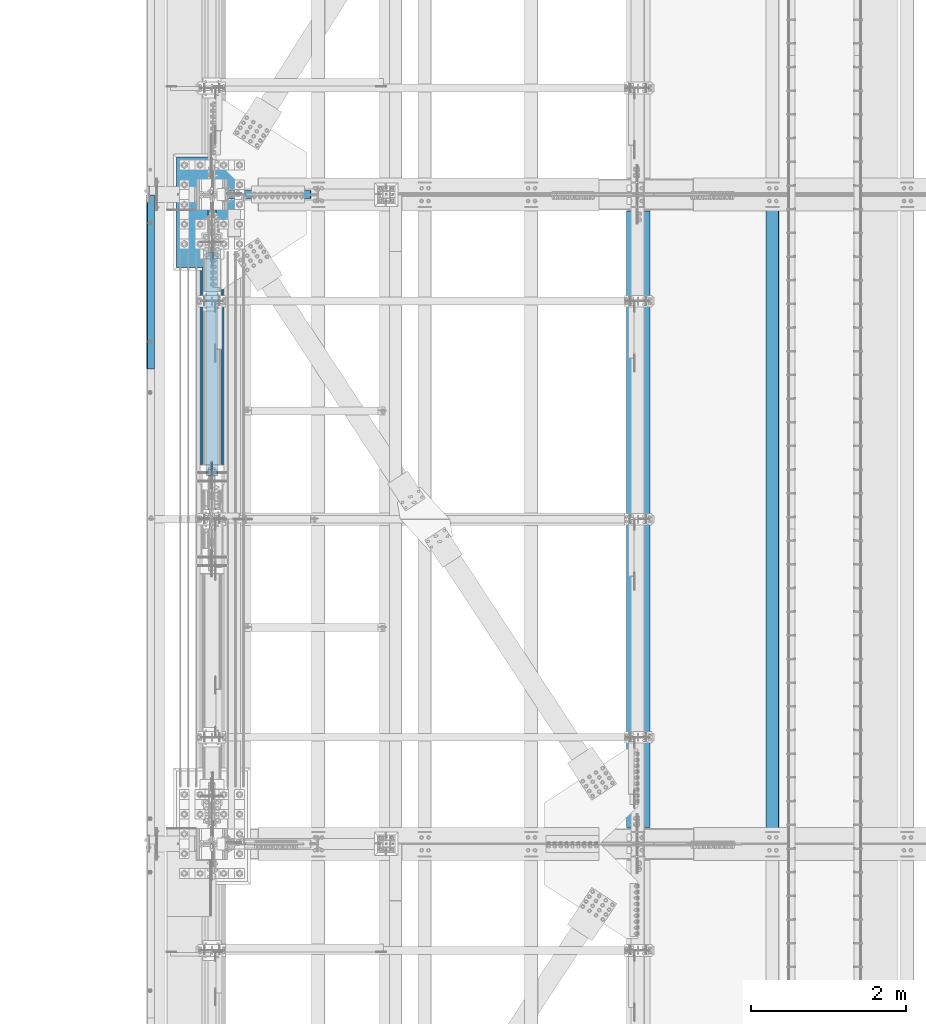
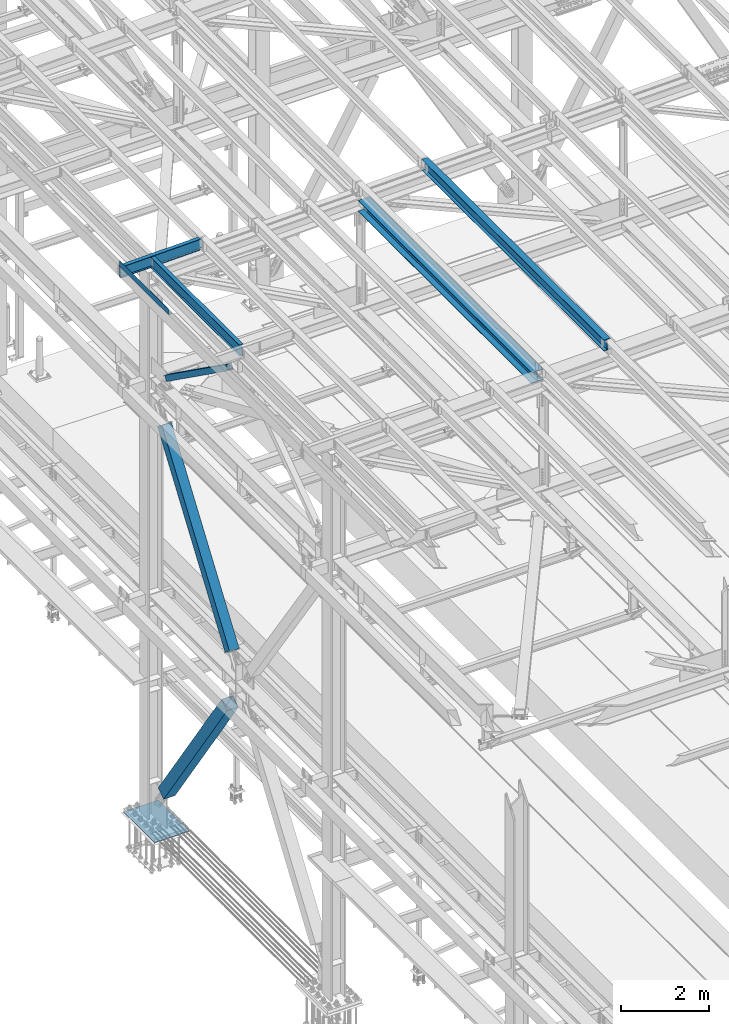
# One storey, part 1872 of 3843: 6 beams, 3 members, 9 elements without a shape of their own.
"""IFC2X3 building model written with IfcOpenShell, lengths in millimetres."""

from ifc_helpers import new_model, si_unit, frame, origin_with_axes, place, context, subcontext, project, spatial, faceted_brep, material, type_object, element, aggregate, save


model = new_model("IFC2X3")

# Units and contexts
model_context = context("Model", 3, precision=1e-05, world=origin_with_axes())
body_context = subcontext(model_context, "Body", "Model", "MODEL_VIEW")
ifc_project = project(units=[si_unit("LENGTHUNIT", "METRE", prefix="MILLI"), si_unit("AREAUNIT", "SQUARE_METRE"), si_unit("VOLUMEUNIT", "CUBIC_METRE"), si_unit("MASSUNIT", "GRAM", prefix="KILO"), si_unit("TIMEUNIT", "SECOND"), si_unit("PLANEANGLEUNIT", "RADIAN"), si_unit("SOLIDANGLEUNIT", "STERADIAN"), si_unit("THERMODYNAMICTEMPERATUREUNIT", "DEGREE_CELSIUS"), si_unit("LUMINOUSINTENSITYUNIT", "LUMEN")], contexts=[model_context])

# Site, building, storey
site_placement = place(None, origin_with_axes())
site = spatial("IfcSite", under=ifc_project, at=site_placement, CompositionType="ELEMENT")
building_placement = place(site_placement, origin_with_axes())
building = spatial("IfcBuilding", under=site, at=building_placement, Name="Undefined", CompositionType="ELEMENT")
storey_placement = place(building_placement, origin_with_axes())
storey = spatial("IfcBuildingStorey", under=building, at=storey_placement, Name="Undefined", CompositionType="ELEMENT", Elevation=0.0)

# Assembly, beam
assembly_1_placement = place(storey_placement, origin_with_axes())
assembly_1 = element("IfcElementAssembly", 1, at=assembly_1_placement, inside=storey, Name="BEAM", AssemblyPlace="NOTDEFINED", PredefinedType="RIGID_FRAME")
ifc_material_1 = material(Name="STEEL/A992")
beam_type_1 = type_object("IfcBeamType", Name="W12X26", PredefinedType="NOTDEFINED")
beam_1_placement = place(assembly_1_placement, frame((43792.659262336, 67272.0069474792, 45765.7787150641), z_axis=(-0.0211520979882261, 0.000687434000021311, 0.99977603301199), x_axis=(2.80000003111667e-08, 0.999999763612031, -0.000687586999733484)))
beam_1 = element("IfcBeam", 2, at=beam_1_placement, type_object=beam_type_1, material=ifc_material_1, Name="BEAM", ObjectType="W12X26", context=body_context, shape_type="Brep", body=[
    faceted_brep([(12.7011867508554, 82.5499999994354, -155.575000000346), (12.6946535115567, 82.5499999997701, -146.050000000309), (8343.89663442646, 82.5499999789899, -146.04999997226), (8343.90319267353, 82.5500000004031, -155.575000008612), (12.6935013104521, 3.17499999993015, -146.050000000505), (8343.89549077737, 3.17499997853884, -146.049999971998), (12.4927018611488, 3.17500000013388, 146.050000000476), (8343.69467136807, 3.17500001817098, 146.04999998054), (12.4938540622534, 82.5499999999884, 146.050000000665), (8343.69582356917, 82.5500000180327, 146.049999980729), (12.4873062541155, 82.5499999999956, 155.575000000696), (8343.68927576105, 82.5500000180327, 155.574999980752), (12.4849096757971, -82.5499999997046, 155.575000000303), (8343.68687918273, -82.5499999816529, 155.574999980374), (12.4914574839349, -82.5499999997119, 146.050000000272), (8343.69342699085, -82.5499999816675, 146.049999980336), (12.4926096850395, -3.17499999985739, 146.050000000454), (8343.69457919199, -3.17499998181302, 146.049999980525), (12.6934091343574, -3.17500000006839, -146.050000000512), (8343.89539928547, -3.17500002148154, -146.049999971976), (12.6922569332237, -82.5499999999156, -146.050000000709), (8343.89425563636, -82.5500000219035, -146.049999971714), (12.6988191383571, -82.5500000002576, -155.574999999757), (8343.90080034929, -82.5500000008251, -155.574999980301)], [[[0, 1, 2, 3]], [[1, 4, 5, 2]], [[4, 6, 7, 5]], [[6, 8, 9, 7]], [[8, 10, 11, 9]], [[10, 12, 13, 11]], [[12, 14, 15, 13]], [[14, 16, 17, 15]], [[16, 18, 19, 17]], [[18, 20, 21, 19]], [[20, 22, 23, 21]], [[22, 0, 3, 23]], [[5, 7, 9, 11, 13, 15, 17, 19, 21, 23, 3, 2]], [[22, 20, 18, 16, 14, 12, 10, 8, 6, 4, 1, 0]]]),
])
aggregate(assembly_1, [beam_1])

assembly_2_placement = place(storey_placement, origin_with_axes())
assembly_2 = element("IfcElementAssembly", 3, at=assembly_2_placement, inside=storey, Name="BEAM", AssemblyPlace="NOTDEFINED", PredefinedType="RIGID_FRAME")
ifc_material_2 = material(Name="STEEL/A36")
beam_type_2 = type_object("IfcBeamType", PredefinedType="NOTDEFINED")
beam_2_placement = place(assembly_2_placement, frame((35839.310111032, 74504.55, 45717.1843160678), z_axis=(0.0, -1.0, 0.0), x_axis=(-0.999776270257024, 0.0, -0.0211520550054595)))
beam_2 = element("IfcBeam", 4, at=beam_2_placement, type_object=beam_type_2, material=ifc_material_2, Name="BENT_PLATE", context=body_context, shape_type="Brep", body=[
    faceted_brep([(-7.27595761418343e-12, -4.77739376947284e-08, 1120.775), (-7.27595761418343e-12, -3.17500000000291, 1117.60000004771), (95.2499999984138, -3.17499999993015, 1117.60000004771), (98.4249999509411, -4.77011781185865e-08, 1120.775), (95.2499999992069, -161.924999997405, 1117.60000004772), (98.4249999517488, -161.924999997391, 1120.775), (-7.27595761418343e-12, -3.17500000000291, -1120.775), (95.2499999984138, -3.17499999993015, -1120.775), (-7.27595761418343e-12, 3.17499999998836, 1120.775), (-7.27595761418343e-12, 3.17499999998836, -1120.775), (101.599999998383, 3.17500000006112, 1120.775), (101.599999998383, 3.17500000006112, -1120.775), (101.599999999198, -161.924999997369, 1120.775), (101.599999999198, -161.924999997369, -1120.775), (95.2499999992069, -161.924999997405, -1120.775)], [[[0, 1, 2, 3]], [[3, 2, 4, 5]], [[6, 7, 2, 1]], [[8, 9, 6, 1, 0]], [[9, 8, 10, 11]], [[11, 10, 12, 13]], [[12, 10, 8, 0, 3, 5]], [[7, 14, 4, 2]], [[7, 6, 9, 11, 13, 14]], [[14, 13, 12, 5, 4]]]),
])
aggregate(assembly_2, [beam_2])

assembly_3_placement = place(storey_placement, origin_with_axes())
assembly_3 = element("IfcElementAssembly", 5, at=assembly_3_placement, inside=storey, Name="BEAM", AssemblyPlace="NOTDEFINED", PredefinedType="RIGID_FRAME")
beam_type_3 = type_object("IfcBeamType", Name="W12X19", PredefinedType="NOTDEFINED")
beam_3_placement = place(assembly_3_placement, frame((35741.5466639417, 75628.5000000002, 45557.9190599814), z_axis=(-0.0243309620078727, 0.0, 0.999703958323549), x_axis=(0.999703958323549, 0.0, 0.0243309620078731)))
beam_3 = element("IfcBeam", 6, at=beam_3_placement, type_object=beam_type_3, material=ifc_material_1, Name="BEAM", ObjectType="W12X19", context=body_context, shape_type="Brep", body=[
    faceted_brep([(2104.49644602991, -3.17500000000291, -144.462500005306), (2104.49644602991, -50.8000000000029, -144.462500005306), (2104.46615934558, -50.8000000000029, -153.987500005322), (2104.46615934558, 50.8000000000029, -153.987500005322), (2104.49644602991, 50.8000000000029, -144.462500005306), (2104.49644602991, 3.17500000000291, -144.462500005306), (2104.50753585254, 3.17500000000291, -140.974810188054), (2104.50753585254, -3.17500000000291, -140.974810188054), (2105.48971442616, 3.17500000000291, -136.117829138602), (2105.48971442616, -3.17500000000291, -136.117829138602), (2108.25581528653, 3.17500000000291, -132.006427224958), (2108.25581528653, -3.17500000000291, -132.006427224958), (2112.38472465244, 3.17500000000291, -129.266528118555), (2112.38472465244, -3.17500000000291, -129.266528118555), (2117.24785350157, 3.17500000000291, -128.315256621056), (2117.24785350157, -3.17500000000291, -128.315256621056), (2187.09750056666, -3.17500000000291, -128.537357850546), (2187.09750056666, 3.17500000000291, -128.537357850546), (4.36557456851006e-11, 3.17500000000291, 144.462499999994), (4.36557456851006e-11, 50.8000000000029, 144.462499999994), (2105.41514961354, 50.8000000000029, 144.462500000773), (2105.41514961354, 3.17500000000291, 144.462500000773), (-3.63797880709171e-11, -50.8000000000029, -153.987499999988), (-3.63797880709171e-11, -50.8000000000029, -144.46249999998), (-3.63797880709171e-11, -3.17500000000291, -144.46249999998), (4.36557456851006e-11, -3.17500000000291, 144.462499999994), (4.36557456851006e-11, -50.8000000000029, 144.462499999994), (3.63797880709171e-11, -50.8000000000029, 153.987499999988), (3.63797880709171e-11, 50.8000000000029, 153.987499999988), (-3.63797880709171e-11, 3.17500000000291, -144.46249999998), (-3.63797880709171e-11, 50.8000000000029, -144.46249999998), (-3.63797880709171e-11, 50.8000000000029, -153.987499999988), (2105.41514961354, -3.17500000000291, 144.462500000773), (2105.41514961354, -50.8000000000029, 144.462500000773), (2105.44538605725, -50.8000000000029, 153.987500000767), (2105.44538605725, 50.8000000000029, 153.987500000767), (2105.40603627673, -3.17500000000291, 141.598760949964), (2105.40603627673, 3.17500000000291, 141.598760949964), (2106.35730777424, -3.17500000000291, 136.735632100834), (2106.35730777424, 3.17500000000291, 136.735632100834), (2109.09720688066, -3.17500000000291, 132.606722734927), (2109.09720688066, 3.17500000000291, 132.606722734927), (2113.20860879429, -3.17500000000291, 129.840621874551), (2113.20860879429, 3.17500000000291, 129.840621874551), (2118.06558984374, -3.17500000000291, 128.858443300931), (2118.06558984374, 3.17500000000291, 128.858443300931), (2187.91523691027, -3.17500000000291, 128.636342071433), (2187.91523691027, 3.17500000000291, 128.636342071433)], [[[0, 1, 2, 3, 4, 5, 6, 7]], [[7, 6, 8, 9]], [[9, 8, 10, 11]], [[11, 10, 12, 13]], [[13, 12, 14, 15]], [[16, 15, 14, 17]], [[18, 19, 20, 21]], [[22, 23, 24, 25, 26, 27, 28, 19, 18, 29, 30, 31]], [[26, 25, 32, 33]], [[27, 26, 33, 34]], [[28, 27, 34, 35]], [[19, 28, 35, 20]], [[34, 33, 32, 36, 37, 21, 20, 35]], [[38, 39, 37, 36]], [[40, 41, 39, 38]], [[42, 43, 41, 40]], [[44, 45, 43, 42]], [[46, 47, 45, 44]], [[47, 46, 16, 17]], [[12, 10, 8, 6, 5, 29, 18, 21, 37, 39, 41, 43, 45, 47, 17, 14]], [[30, 29, 5, 4]], [[31, 30, 4, 3]], [[22, 31, 3, 2]], [[23, 22, 2, 1]], [[24, 23, 1, 0]], [[46, 44, 42, 40, 38, 36, 32, 25, 24, 0, 7, 9, 11, 13, 15, 16]]]),
])
aggregate(assembly_3, [beam_3])

assembly_4_placement = place(storey_placement, origin_with_axes())
assembly_4 = element("IfcElementAssembly", 7, at=assembly_4_placement, inside=storey, Name="BEAM", AssemblyPlace="NOTDEFINED", PredefinedType="RIGID_FRAME")
beam_4_placement = place(assembly_4_placement, frame((36575.9999999884, 71450.2, 45575.6071293693), z_axis=(0.0, 0.0, 1.0), x_axis=(0.0, 1.0, 0.0)))
beam_4 = element("IfcBeam", 8, at=beam_4_placement, type_object=beam_type_3, material=ifc_material_1, Name="BEAM", ObjectType="W12X19", context=body_context, shape_type="Brep", body=[
    faceted_brep([(4111.62499999991, -3.17500000000291, -144.462500000001), (4111.62499999991, -50.8000000000029, -144.462500000001), (4111.62499999991, -50.8000000000029, -153.987500000003), (4111.62499999991, 50.8000000000029, -153.987500000003), (4111.62499999991, 50.8000000000029, -144.462500000001), (4111.62499999991, 3.17500000000291, -144.462500000001), (4111.62499999991, 3.17500000000291, -141.287499808204), (4111.62499999991, -3.17500000000291, -141.287499808204), (4112.5917299225, 3.17500000000291, -136.427420290158), (4112.5917299225, -3.17500000000291, -136.427420290158), (4115.34474382298, 3.17500000000291, -132.307243822004), (4115.34474382298, -3.17500000000291, -132.307243822004), (4119.46492029114, 3.17500000000291, -129.55422992153), (4119.46492029114, -3.17500000000291, -129.55422992153), (4124.32499980918, 3.17500000000291, -128.587499998939), (4124.32499980918, -3.17500000000291, -128.587499998939), (4162.42499999992, -3.17500000000291, -128.587499998939), (4162.42499999992, 3.17500000000291, -128.587499998939), (4111.62499999991, 50.8000000000029, 144.462500000001), (4111.62499999991, 3.17500000000291, 144.462500000001), (66.6750000000175, 3.17500000000291, 144.462500000001), (66.6750000000175, 50.8000000000029, 144.462500000001), (66.6750000000175, -3.17500000000291, -141.287499808226), (66.6750000000175, 3.17500000000291, -141.287499808226), (66.6750000000175, 3.17500000000291, -144.462500000001), (66.6750000000175, 50.8000000000029, -144.462500000001), (66.6750000000175, 50.8000000000029, -153.987500000003), (66.6750000000175, -50.8000000000029, -153.987500000003), (66.6750000000175, -50.8000000000029, -144.462500000001), (66.6750000000175, -3.17500000000291, -144.462500000001), (65.7082700774336, -3.17500000000291, -136.42742029018), (65.7082700774336, 3.17500000000291, -136.42742029018), (62.9552561769524, -3.17500000000291, -132.307243822026), (62.9552561769524, 3.17500000000291, -132.307243822026), (58.8350797087915, -3.17500000000291, -129.554229921552), (58.8350797087915, 3.17500000000291, -129.554229921552), (53.9750001907523, -3.17500000000291, -128.587499998961), (53.9750001907523, 3.17500000000291, -128.587499998961), (15.8750000000146, -3.17500000000291, -128.587499998961), (15.8750000000146, 3.17500000000291, -128.587499998961), (15.8750000000146, -3.17500000000291, 128.587500001042), (15.8750000000146, 3.17500000000291, 128.587500001042), (15.8750000000146, 3.17500000000291, 115.887500001612), (15.8750000000146, 3.17500000000291, -114.712499998386), (53.9750001907523, -3.17500000000291, 128.587500001042), (53.9750001907523, 3.17500000000291, 128.587500001042), (58.8350797087915, -3.17500000000291, 129.554229923633), (58.8350797087915, 3.17500000000291, 129.554229923633), (62.9552561769524, -3.17500000000291, 132.307243824107), (62.9552561769524, 3.17500000000291, 132.307243824107), (65.7082700774336, -3.17500000000291, 136.427420292261), (65.7082700774336, 3.17500000000291, 136.427420292261), (66.6750000000175, -3.17500000000291, 141.287499810307), (66.6750000000175, 3.17500000000291, 141.287499810307), (66.6750000000175, -50.8000000000029, 153.987500000003), (66.6750000000175, 50.8000000000029, 153.987500000003), (66.6750000000175, -3.17500000000291, 144.462500000001), (66.6750000000175, -50.8000000000029, 144.462500000001), (4111.62499999991, -3.17500000000291, 144.462500000001), (4111.62499999991, -50.8000000000029, 144.462500000001), (4111.62499999991, -50.8000000000029, 153.987500000003), (4111.62499999991, 50.8000000000029, 153.987500000003), (4111.62499999991, -3.17500000000291, 141.287499810329), (4111.62499999991, 3.17500000000291, 141.287499810329), (4112.5917299225, -3.17500000000291, 136.427420292282), (4112.5917299225, 3.17500000000291, 136.427420292282), (4115.34474382298, -3.17500000000291, 132.307243824129), (4115.34474382298, 3.17500000000291, 132.307243824129), (4119.46492029114, -3.17500000000291, 129.554229923655), (4119.46492029114, 3.17500000000291, 129.554229923655), (4124.32499980918, -3.17500000000291, 128.587500001064), (4124.32499980918, 3.17500000000291, 128.587500001064), (4162.42499999992, -3.17500000000291, 128.587500001064), (4162.42499999992, 3.17500000000291, 128.587500001064), (4162.42499999992, 3.17500000000291, -114.712499998423), (4162.42499999992, 3.17500000000291, 115.887500001576)], [[[0, 1, 2, 3, 4, 5, 6, 7]], [[7, 6, 8, 9]], [[9, 8, 10, 11]], [[11, 10, 12, 13]], [[13, 12, 14, 15]], [[16, 15, 14, 17]], [[18, 19, 20, 21]], [[22, 23, 24, 25, 26, 27, 28, 29]], [[30, 31, 23, 22]], [[32, 33, 31, 30]], [[34, 35, 33, 32]], [[36, 37, 35, 34]], [[38, 39, 37, 36]], [[40, 41, 42, 43, 39, 38]], [[44, 45, 41, 40]], [[46, 47, 45, 44]], [[48, 49, 47, 46]], [[50, 51, 49, 48]], [[52, 53, 51, 50]], [[54, 55, 21, 20, 53, 52, 56, 57]], [[58, 59, 57, 56]], [[59, 60, 54, 57]], [[60, 61, 55, 54]], [[61, 18, 21, 55]], [[60, 59, 58, 62, 63, 19, 18, 61]], [[64, 65, 63, 62]], [[66, 67, 65, 64]], [[68, 69, 67, 66]], [[70, 71, 69, 68]], [[72, 73, 71, 70]], [[74, 75, 73, 72, 16, 17]], [[33, 35, 37, 39, 43, 42, 41, 45, 47, 49, 51, 53, 20, 19, 63, 65, 67, 69, 71, 73, 75, 74, 17, 14, 12, 10, 8, 6, 5, 24, 23, 31]], [[5, 4, 25, 24]], [[4, 3, 26, 25]], [[3, 2, 27, 26]], [[2, 1, 28, 27]], [[1, 0, 29, 28]], [[0, 7, 9, 11, 13, 15, 16, 72, 70, 68, 66, 64, 62, 58, 56, 52, 50, 48, 46, 44, 40, 38, 36, 34, 32, 30, 22, 29]]]),
])
aggregate(assembly_4, [beam_4])

# Assembly, member
assembly_5_placement = place(storey_placement, origin_with_axes())
assembly_5 = element("IfcElementAssembly", 9, at=assembly_5_placement, inside=storey, Name="None", AssemblyPlace="NOTDEFINED", PredefinedType="RIGID_FRAME")
member_type_1 = type_object("IfcMemberType", Name="HSS10X10X1/4", PredefinedType="NOTDEFINED")
member_1_placement = place(assembly_5_placement, frame((36576.0, 71932.0945853412, 36941.8524737922), z_axis=(1.0, 0.0, 0.0), x_axis=(0.0, 0.572746499261054, 0.819732546373637)))
member_1 = element("IfcMember", 10, at=member_1_placement, type_object=member_type_1, material=ifc_material_1, Name="None", ObjectType="HSS10X10X1/4", context=body_context, shape_type="Brep", body=[
    faceted_brep([(2.00088834390044e-10, 120.650000000089, -120.649999999994), (-2.03726813197136e-10, -120.650000000081, -120.649999999994), (5403.85000024675, -120.650000015012, -120.650000000001), (5403.85000024701, 120.649999984038, -120.650000000001), (-2.03726813197136e-10, -120.650000000081, 120.649999999994), (5403.85000024675, -120.650000015012, 120.650000000001), (2.00088834390044e-10, 120.650000000089, 120.649999999994), (5403.85000024701, 120.649999984038, 120.650000000001), (2.16459739021957e-10, 127.000000000087, -127.0), (2.16459739021957e-10, 127.000000000087, 127.0), (5403.85000024701, 126.999999984007, 127.0), (5403.85000024701, 126.999999984007, -127.0), (-2.14640749618411e-10, -127.00000000008, 127.0), (5403.85000024675, -127.000000014988, 127.0), (-2.14640749618411e-10, -127.00000000008, -127.0), (5403.85000024675, -127.000000014988, -127.0)], [[[0, 1, 2, 3]], [[1, 4, 5, 2]], [[4, 6, 7, 5]], [[6, 0, 3, 7]], [[8, 9, 10, 11]], [[9, 12, 13, 10]], [[12, 14, 15, 13]], [[14, 8, 11, 15]], [[13, 15, 11, 10], [5, 7, 3, 2]], [[14, 12, 9, 8], [6, 4, 1, 0]]]),
])
aggregate(assembly_5, [member_1])

assembly_6_placement = place(storey_placement, origin_with_axes())
assembly_6 = element("IfcElementAssembly", 11, at=assembly_6_placement, inside=storey, Name="None", AssemblyPlace="NOTDEFINED", PredefinedType="RIGID_FRAME")
member_type_2 = type_object("IfcMemberType", Name="HSS12X12X5/16", PredefinedType="NOTDEFINED")
member_2_placement = place(assembly_6_placement, frame((36576.0000061035, 74926.1485506377, 31186.1398748412), z_axis=(-1.0, 0.0, 0.0), x_axis=(0.0, -0.565762265008601, 0.824568408012542)))
member_2 = element("IfcMember", 12, at=member_2_placement, type_object=member_type_2, material=ifc_material_1, Name="None", ObjectType="HSS12X12X5/16", context=body_context, shape_type="Brep", body=[
    faceted_brep([(-2.61934474110603e-10, 144.462500000002, -144.462500000001), (2.61934474110603e-10, -144.462499999993, -144.462500000001), (5124.45041186737, -144.462499974092, -144.462500000001), (5124.45041186616, 144.462500026799, -144.462500000001), (2.61934474110603e-10, -144.462499999993, 144.462500000001), (5124.45041186737, -144.462499974092, 144.462500000001), (-2.61934474110603e-10, 144.462500000002, 144.462500000001), (5124.45041186616, 144.462500026799, 144.462500000001), (-2.7648638933897e-10, 152.400000000002, -152.400000000001), (-2.7648638933897e-10, 152.400000000002, 152.400000000001), (5124.45041186612, 152.400000026828, 152.400000000001), (5124.45041186612, 152.400000026828, -152.400000000001), (2.83762346953154e-10, -152.399999999993, 152.400000000001), (5124.4504118674, -152.399999974121, 152.400000000001), (2.83762346953154e-10, -152.399999999993, -152.400000000001), (5124.4504118674, -152.399999974121, -152.400000000001)], [[[0, 1, 2, 3]], [[1, 4, 5, 2]], [[4, 6, 7, 5]], [[6, 0, 3, 7]], [[8, 9, 10, 11]], [[9, 12, 13, 10]], [[12, 14, 15, 13]], [[14, 8, 11, 15]], [[13, 15, 11, 10], [5, 7, 3, 2]], [[14, 12, 9, 8], [6, 4, 1, 0]]]),
])
aggregate(assembly_6, [member_2])

assembly_7_placement = place(storey_placement, origin_with_axes())
assembly_7 = element("IfcElementAssembly", 13, at=assembly_7_placement, inside=storey, AssemblyPlace="NOTDEFINED", PredefinedType="RIGID_FRAME")
ifc_material_3 = material()
member_type_3 = type_object("IfcMemberType", Name="HSS6X6X3/8", PredefinedType="NOTDEFINED")
member_3_placement = place(assembly_7_placement, frame((36575.9999999316, 71450.2000002264, 45210.4124997862), z_axis=(1.0, 0.0, 0.0), x_axis=(0.0, 0.814318393718894, -0.580418429799641)))
member_3 = element("IfcMember", 14, at=member_3_placement, type_object=member_type_3, material=ifc_material_3, ObjectType="HSS6X6X3/8", context=body_context, shape_type="Brep", body=[
    faceted_brep([(735.102363335427, -76.2000000014959, 7.93750000002183), (735.10236333542, -66.6750000014727, 7.93750000002183), (835.114863341114, -66.6750000016327, 7.93750000002183), (835.114863341099, -76.2000000016706, 7.93750000002183), (838.152413085547, -66.6750000016473, 7.33329378932831), (838.152413085525, -76.2000000016706, 7.33329378932831), (840.727523416841, -66.6750000016473, 5.61266007569066), (840.727523416834, -76.2000000016706, 5.61266007569066), (842.4481571305, -66.6750000016473, 3.03754974441836), (842.448157130493, -76.2000000016851, 3.03754974441836), (835.114863341099, -76.2000000016706, -7.93749999997817), (835.114863341114, -66.6750000016327, -7.93749999997817), (735.10236333542, -66.6750000014727, -7.93749999997817), (735.102363335427, -76.2000000014959, -7.93749999997817), (838.152413085525, -76.2000000016706, -7.33329378928465), (838.152413085547, -66.6750000016473, -7.33329378928465), (840.727523416834, -76.2000000016706, -5.612660075647), (840.727523416841, -66.6750000016473, -5.612660075647), (842.448157130493, -76.2000000016851, -3.0375497443747), (842.4481571305, -66.6750000016473, -3.0375497443747), (843.052363341194, -76.2000000016706, 2.18278728425503e-11), (843.052363341201, -66.6750000016473, 2.18278728425503e-11), (735.102363335423, 66.6749999989988, 7.93750000002183), (735.102363335423, 76.1999999990512, 7.93750000002183), (835.114863341361, 76.1999999988911, 7.93750000002183), (835.11486334134, 66.6749999988533, 7.93750000002183), (838.152413085787, 76.1999999988766, 7.33329378932831), (838.152413085765, 66.6749999988388, 7.33329378932831), (840.727523417074, 76.1999999988766, 5.61266007569066), (840.727523417067, 66.6749999988533, 5.61266007569066), (842.448157130733, 76.1999999988766, 3.03754974441836), (842.448157130733, 66.6749999988388, 3.03754974441836), (835.11486334134, 66.6749999988533, -7.93749999997817), (835.114863341361, 76.1999999988911, -7.93749999997817), (735.102363335423, 76.1999999990512, -7.93749999997817), (735.102363335423, 66.6749999989988, -7.93749999997817), (838.152413085765, 66.6749999988388, -7.33329378928465), (838.152413085787, 76.1999999988766, -7.33329378928465), (840.727523417067, 66.6749999988533, -5.612660075647), (840.727523417074, 76.1999999988766, -5.612660075647), (842.448157130733, 66.6749999988388, -3.0375497443747), (842.448157130733, 76.1999999988766, -3.0375497443747), (843.052363341434, 66.6749999988388, 2.18278728425503e-11), (843.052363341441, 76.1999999988766, 2.18278728425503e-11), (735.10236333542, -66.6750000014727, 66.6750000000029), (735.102363335423, 66.6749999989988, 66.6750000000029), (4171.65947153774, 66.674999993309, 66.6750000000029), (4171.65947153775, -66.6750000071625, 66.6750000000029), (735.102363335423, 76.1999999990512, 76.1999999999971), (4171.65947153774, 76.1999999933469, 76.1999999999971), (4171.65947153774, 76.1999999933469, 20.6374999999971), (4071.64697153206, 76.1999999935069, 20.6374999999971), (4068.60942178765, 76.1999999935215, 20.0332937893036), (4066.03431145635, 76.1999999935215, 18.3126600756659), (4064.31367774269, 76.1999999935215, 15.7375497443936), (4063.70947153199, 76.1999999935215, 12.6999999999971), (4064.31367774269, 76.1999999935215, 9.66245025560056), (4066.03431145635, 76.1999999935215, 7.08733992432826), (4068.60942178765, 76.1999999935215, 5.36670621069061), (4071.64697153206, 76.1999999935069, 4.76249999999709), (4171.65947153774, 76.1999999933469, 4.76249999999709), (4171.65947153774, 76.1999999933469, -76.1999999999971), (735.102363335423, 76.1999999990512, -76.1999999999971), (4171.65947153774, 66.674999993309, 20.6374999999971), (4071.64697153206, 66.6749999934837, 20.6374999999971), (4068.60942178763, 66.6749999934691, 20.0332937893036), (4066.03431145632, 66.6749999934982, 18.3126600756659), (4064.31367774266, 66.6749999934982, 15.7375497443936), (4063.70947153198, 66.6749999934837, 12.6999999999971), (4064.31367774266, 66.6749999934982, 9.66245025560056), (4066.03431145632, 66.6749999934982, 7.08733992432826), (4068.60942178763, 66.6749999934691, 5.36670621069061), (4071.64697153206, 66.6749999934837, 4.76249999999709), (4171.65947153774, 66.674999993309, 4.76249999999709), (735.102363335423, 66.6749999989988, -66.6750000000029), (735.10236333542, -66.6750000014727, -66.6750000000029), (4171.65947153775, -66.6750000071625, -66.6750000000029), (4171.65947153774, 66.674999993309, -66.6750000000029), (4068.60942178738, -76.2000000070402, 20.0332937893036), (4068.60942178741, -66.6750000070024, 20.0332937893036), (4071.64697153183, -66.6750000070024, 20.6374999999971), (4071.64697153182, -76.2000000070402, 20.6374999999971), (4066.03431145609, -76.2000000070257, 18.3126600756659), (4066.03431145611, -66.6750000070024, 18.3126600756659), (4064.31367774244, -76.2000000070257, 15.7375497443936), (4064.31367774246, -66.6750000070024, 15.7375497443936), (4063.70947153174, -76.2000000070257, 12.6999999999971), (4063.70947153176, -66.6750000070024, 12.6999999999971), (4064.31367774244, -76.2000000070257, 9.66245025560056), (4064.31367774246, -66.6750000070024, 9.66245025560056), (4066.03431145609, -76.2000000070257, 7.08733992432826), (4066.03431145611, -66.6750000070024, 7.08733992432826), (4068.60942178738, -76.2000000070402, 5.36670621069061), (4068.60942178741, -66.6750000070024, 5.36670621069061), (4071.64697153182, -76.2000000070402, 4.76249999999709), (4071.64697153183, -66.6750000070024, 4.76249999999709), (4171.65947153775, -76.2000000072003, 4.76249999999709), (4171.65947153775, -66.6750000071625, 4.76249999999709), (4171.65947153775, -76.2000000072003, -76.1999999999971), (735.102363335427, -76.2000000014959, -76.1999999999971), (4171.65947153775, -66.6750000071625, 20.6374999999971), (4171.65947153775, -76.2000000072003, 20.6374999999971), (4171.65947153775, -76.2000000072003, 76.1999999999971), (735.102363335427, -76.2000000014959, 76.1999999999971)], [[[0, 1, 2, 3]], [[3, 2, 4, 5]], [[5, 4, 6, 7]], [[7, 6, 8, 9]], [[10, 11, 12, 13]], [[14, 15, 11, 10]], [[16, 17, 15, 14]], [[18, 19, 17, 16]], [[20, 21, 19, 18]], [[9, 8, 21, 20]], [[22, 23, 24, 25]], [[25, 24, 26, 27]], [[27, 26, 28, 29]], [[29, 28, 30, 31]], [[32, 33, 34, 35]], [[36, 37, 33, 32]], [[38, 39, 37, 36]], [[40, 41, 39, 38]], [[42, 43, 41, 40]], [[31, 30, 43, 42]], [[44, 45, 46, 47]], [[28, 26, 24, 23, 48, 49, 50, 51, 52, 53, 54, 55, 56, 57, 58, 59, 60, 61, 62, 34, 33, 37, 39, 41, 43, 30]], [[63, 64, 51, 50]], [[65, 52, 51, 64]], [[66, 53, 52, 65]], [[67, 54, 53, 66]], [[68, 55, 54, 67]], [[69, 56, 55, 68]], [[70, 57, 56, 69]], [[71, 58, 57, 70]], [[72, 59, 58, 71]], [[73, 60, 59, 72]], [[74, 75, 76, 77]], [[78, 79, 80, 81]], [[82, 83, 79, 78]], [[84, 85, 83, 82]], [[86, 87, 85, 84]], [[88, 89, 87, 86]], [[90, 91, 89, 88]], [[92, 93, 91, 90]], [[94, 95, 93, 92]], [[96, 97, 95, 94]], [[98, 61, 60, 73, 77, 76, 97, 96]], [[99, 62, 61, 98]], [[75, 74, 35, 34, 62, 99, 13, 12]], [[6, 4, 2, 1, 44, 47, 100, 80, 79, 83, 85, 87, 89, 91, 93, 95, 97, 76, 75, 12, 11, 15, 17, 19, 21, 8]], [[101, 81, 80, 100]], [[47, 46, 63, 50, 49, 102, 101, 100]], [[48, 103, 102, 49]], [[16, 14, 10, 13, 99, 98, 96, 94, 92, 90, 88, 86, 84, 82, 78, 81, 101, 102, 103, 0, 3, 5, 7, 9, 20, 18]], [[103, 48, 23, 22, 45, 44, 1, 0]], [[38, 36, 32, 35, 74, 77, 73, 72, 71, 70, 69, 68, 67, 66, 65, 64, 63, 46, 45, 22, 25, 27, 29, 31, 42, 40]]]),
])
aggregate(assembly_7, [member_3])

# Assembly, beam
assembly_8_placement = place(storey_placement, origin_with_axes())
assembly_8 = element("IfcElementAssembly", 15, at=assembly_8_placement, inside=storey, Name="BEAM", AssemblyPlace="NOTDEFINED", PredefinedType="RIGID_FRAME")
beam_type_4 = type_object("IfcBeamType", Name="W12X65", PredefinedType="NOTDEFINED")
beam_5_placement = place(assembly_8_placement, frame((42062.4, 67271.899999999, 45368.1367754596), z_axis=(0.0, 0.000536447000064071, 0.999999856112298), x_axis=(0.0, 0.999999856112298, -0.000536447000060628)))
beam_5 = element("IfcBeam", 16, at=beam_5_placement, type_object=beam_type_4, material=ifc_material_1, Name="BEAM", ObjectType="W12X65", context=body_context, shape_type="Brep", body=[
    faceted_brep([(212.807602385932, 152.400000000001, -153.987499999748), (212.799089828812, 152.400000000001, -138.112499999712), (8143.95022999885, 152.400000000001, -138.112499976436), (8143.95874255597, 152.400000000001, -153.987499976472), (212.799089828812, 4.76249999999709, -138.112499999712), (8143.95022999885, 4.76249999999709, -138.112499976436), (212.650971335097, 4.76249999999709, 138.112500000971), (8143.80211150514, 4.76249999999709, 138.112500024246), (212.650971335097, 152.400000000001, 138.112500000971), (8143.80211150514, 152.400000000001, 138.112500024246), (212.642458777991, 152.400000000001, 153.987500001007), (8143.79359894803, 152.400000000001, 153.987500024283), (212.642458777991, -152.400000000001, 153.987500001007), (8143.79359894803, -152.400000000001, 153.987500024283), (212.650971335097, -152.400000000001, 138.112500000971), (8143.80211150514, -152.400000000001, 138.112500024246), (212.650971335097, -4.76249999999709, 138.112500000971), (8143.80211150514, -4.76249999999709, 138.112500024246), (212.799089828812, -4.76249999999709, -138.112499999712), (8143.95022999885, -4.76249999999709, -138.112499976436), (212.799089828812, -152.400000000001, -138.112499999712), (8143.95022999885, -152.400000000001, -138.112499976436), (212.807602385932, -152.400000000001, -153.987499999748), (8143.95874255597, -152.400000000001, -153.987499976472)], [[[0, 1, 2, 3]], [[1, 4, 5, 2]], [[4, 6, 7, 5]], [[6, 8, 9, 7]], [[8, 10, 11, 9]], [[10, 12, 13, 11]], [[12, 14, 15, 13]], [[14, 16, 17, 15]], [[16, 18, 19, 17]], [[18, 20, 21, 19]], [[20, 22, 23, 21]], [[22, 0, 3, 23]], [[5, 7, 9, 11, 13, 15, 17, 19, 21, 23, 3, 2]], [[22, 20, 18, 16, 14, 12, 10, 8, 6, 4, 1, 0]]]),
])
aggregate(assembly_8, [beam_5])

assembly_9_placement = place(storey_placement, origin_with_axes())
assembly_9 = element("IfcElementAssembly", 17, at=assembly_9_placement, inside=storey, Name="TEMPLATE", AssemblyPlace="NOTDEFINED", PredefinedType="RIGID_FRAME")
ifc_material_4 = material(Name="STEEL/A572-50")
beam_type_5 = type_object("IfcBeamType", PredefinedType="NOTDEFINED")
beam_6_placement = place(assembly_9_placement, frame((37033.1990112305, 75399.9, 30067.25), z_axis=(0.0, -1.0, 0.0), x_axis=(-1.0, 0.0, 0.0)))
beam_6 = element("IfcBeam", 18, at=beam_6_placement, type_object=beam_type_5, material=ifc_material_4, Name="TEMPLATE", context=body_context, shape_type="Brep", body=[
    faceted_brep([(0.0, 6.34999999999854, -711.199999999997), (0.0, 6.34999999999854, 711.200012207031), (914.39802246094, 6.34999999999854, 711.199999999997), (914.39802246094, 6.34999999999854, -711.199999999997), (0.0, -6.34999999999854, 711.200012207031), (914.39802246094, -6.34999999999854, 711.199999999997), (0.0, -6.34999999999854, -711.199999999997), (914.39802246094, -6.34999999999854, -711.199999999997)], [[[0, 1, 2, 3]], [[1, 4, 5, 2]], [[4, 6, 7, 5]], [[6, 0, 3, 7]], [[5, 7, 3, 2]], [[6, 4, 1, 0]]]),
])
aggregate(assembly_9, [beam_6])

save(model, "model.ifc")
